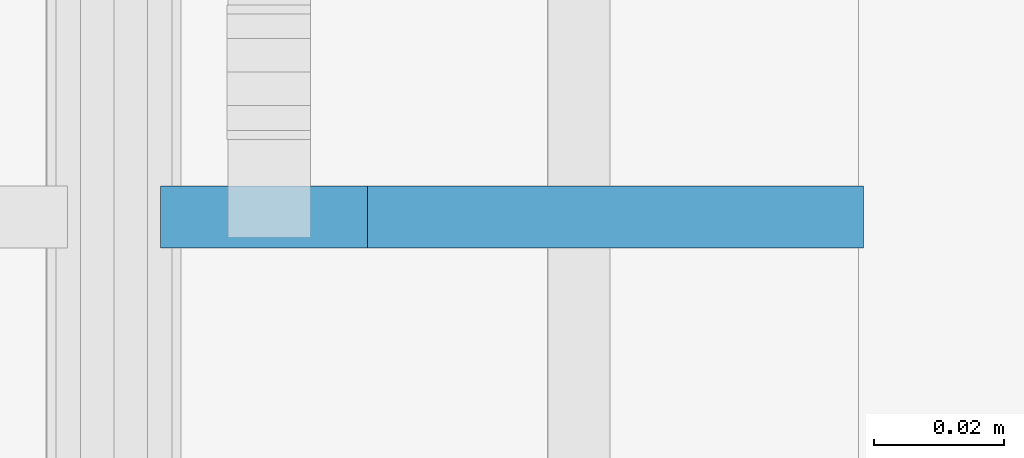
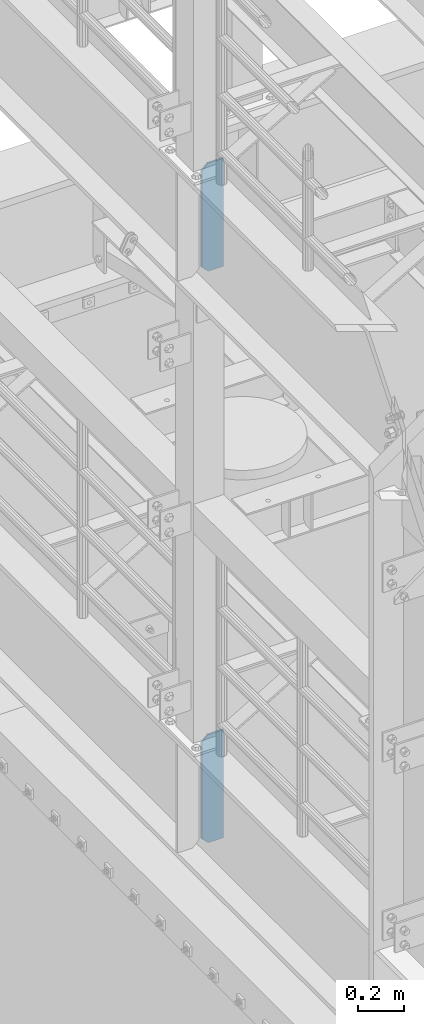
# One storey, part 1710 of 1876: 2 plates, 2 elements without a shape of their own.
"""IFC2X3 building model written with IfcOpenShell, lengths in millimetres."""

from ifc_helpers import new_model, si_unit, frame, origin_with_axes, place, context, subcontext, project, spatial, faceted_brep, material, type_object, element, aggregate, save


model = new_model("IFC2X3")

# Units and contexts
model_context = context("Model", 3, precision=1e-05, world=origin_with_axes())
body_context = subcontext(model_context, "Body", "Model", "MODEL_VIEW")
ifc_project = project(units=[si_unit("LENGTHUNIT", "METRE", prefix="MILLI"), si_unit("AREAUNIT", "SQUARE_METRE"), si_unit("VOLUMEUNIT", "CUBIC_METRE"), si_unit("MASSUNIT", "GRAM", prefix="KILO"), si_unit("TIMEUNIT", "SECOND"), si_unit("PLANEANGLEUNIT", "RADIAN"), si_unit("SOLIDANGLEUNIT", "STERADIAN"), si_unit("THERMODYNAMICTEMPERATUREUNIT", "DEGREE_CELSIUS"), si_unit("LUMINOUSINTENSITYUNIT", "LUMEN")], contexts=[model_context])

# Site, building, storey
site_placement = place(None, origin_with_axes())
site = spatial("IfcSite", under=ifc_project, at=site_placement, CompositionType="ELEMENT")
building_placement = place(site_placement, origin_with_axes())
building = spatial("IfcBuilding", under=site, at=building_placement, Name="Undefined", CompositionType="ELEMENT")
storey_placement = place(building_placement, origin_with_axes())
storey = spatial("IfcBuildingStorey", under=building, at=storey_placement, Name="Undefined", CompositionType="ELEMENT", Elevation=0.0)

# Assembly, plate
assembly_1_placement = place(storey_placement, origin_with_axes())
assembly_1 = element("IfcElementAssembly", 1, at=assembly_1_placement, inside=storey, Name="BEAM", AssemblyPlace="NOTDEFINED", PredefinedType="RIGID_FRAME")
ifc_material = material(Name="STEEL/A36")
plate_type = type_object("IfcPlateType", PredefinedType="NOTDEFINED")
plate_1_placement = place(assembly_1_placement, frame((115.09375, 9652.0, 7556.5), z_axis=(0.0, 0.0, 1.0), x_axis=(-1.0, 0.0, 0.0)))
plate_1 = element("IfcPlate", 2, at=plate_1_placement, type_object=plate_type, material=ifc_material, Name="PLATE", context=body_context, shape_type="Brep", body=[
    faceted_brep([(0.0, -4.76249999999982, 0.0), (0.0, -4.76249999999982, 571.5), (0.0, 4.76249999999982, 571.5), (0.0, 4.76249999999982, 0.0), (76.1999969482422, -4.76249999999982, 571.5), (76.1999969482422, 4.76249999999982, 571.5), (107.949996948242, -4.76249999999982, 539.75), (107.949996948242, 4.76249999999982, 539.75), (107.949996948242, -4.76249999999982, 31.75), (107.949996948242, 4.76249999999982, 31.75), (76.1999969482422, -4.76250000000073, 0.0), (76.1999969482422, 4.76250000000073, 0.0)], [[[0, 1, 2, 3]], [[1, 4, 5, 2]], [[4, 6, 7, 5]], [[6, 8, 9, 7]], [[8, 10, 11, 9]], [[10, 0, 3, 11]], [[5, 7, 9, 11, 3, 2]], [[10, 8, 6, 4, 1, 0]]]),
])
aggregate(assembly_1, [plate_1])

assembly_2_placement = place(storey_placement, origin_with_axes())
assembly_2 = element("IfcElementAssembly", 3, at=assembly_2_placement, inside=storey, Name="BEAM", AssemblyPlace="NOTDEFINED", PredefinedType="RIGID_FRAME")
plate_2_placement = place(assembly_2_placement, frame((115.09375, 9652.0, 4533.9), z_axis=(0.0, 0.0, 1.0), x_axis=(-1.0, 0.0, 0.0)))
plate_2 = element("IfcPlate", 4, at=plate_2_placement, type_object=plate_type, material=ifc_material, Name="PLATE", context=body_context, shape_type="Brep", body=[
    faceted_brep([(0.0, -4.76249999999982, 0.0), (0.0, -4.76249999999982, 571.5), (0.0, 4.76249999999982, 571.5), (0.0, 4.76249999999982, 0.0), (76.1999969482422, -4.76249999999982, 571.5), (76.1999969482422, 4.76249999999982, 571.5), (107.949996948242, -4.76249999999982, 539.75), (107.949996948242, 4.76249999999982, 539.75), (107.949996948242, -4.76249999999982, 31.75), (107.949996948242, 4.76249999999982, 31.75), (76.1999969482422, -4.76250000000073, 0.0), (76.1999969482422, 4.76250000000073, 0.0)], [[[0, 1, 2, 3]], [[1, 4, 5, 2]], [[4, 6, 7, 5]], [[6, 8, 9, 7]], [[8, 10, 11, 9]], [[10, 0, 3, 11]], [[5, 7, 9, 11, 3, 2]], [[10, 8, 6, 4, 1, 0]]]),
])
aggregate(assembly_2, [plate_2])

save(model, "model.ifc")
